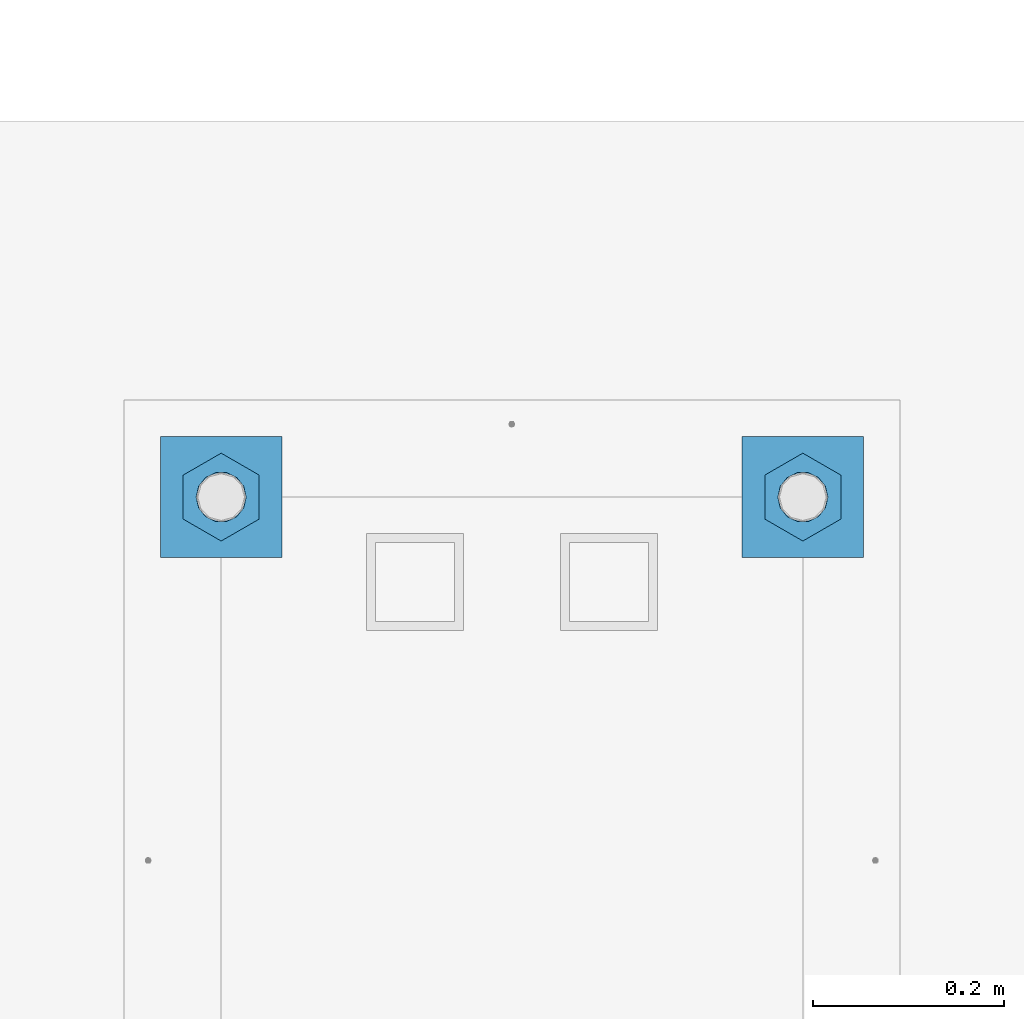
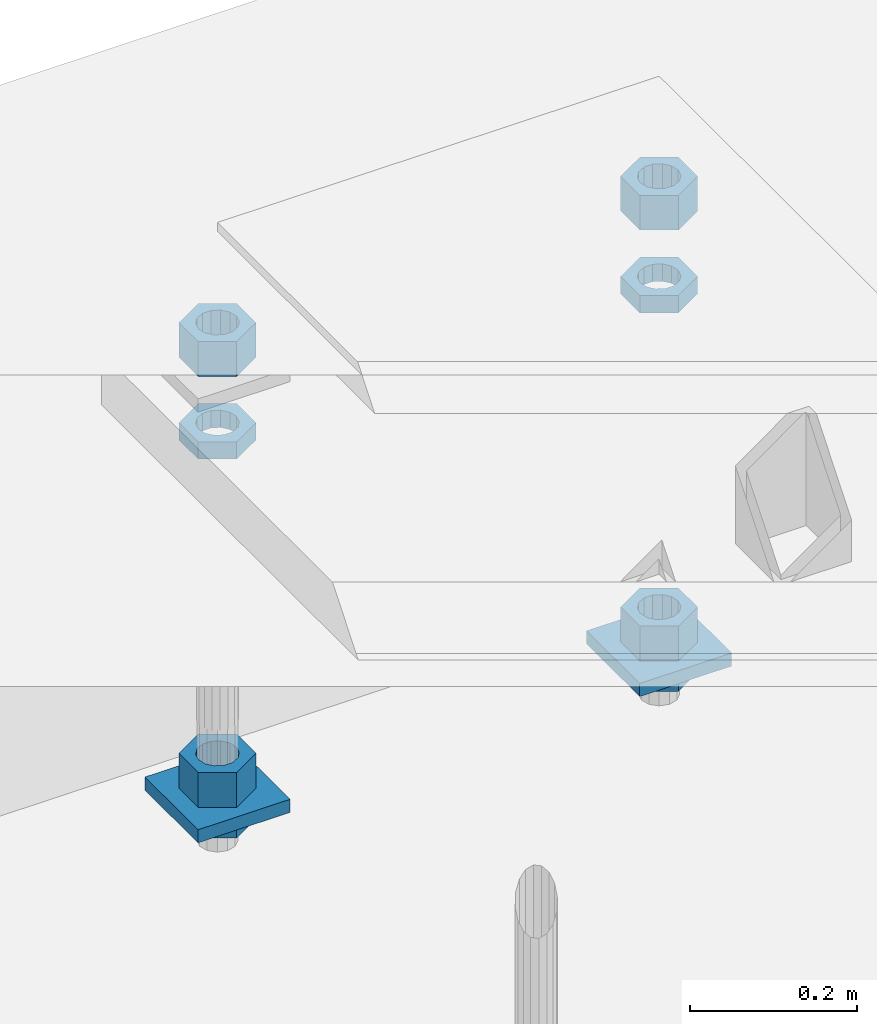
# One storey, part 2720 of 3843: 10 beams, 1 element without a shape of its own.
"""IFC2X3 building model written with IfcOpenShell, lengths in millimetres."""

from ifc_helpers import new_model, si_unit, frame, origin_with_axes, place, context, subcontext, project, spatial, faceted_brep, material, type_object, element, aggregate, save


model = new_model("IFC2X3")

# Units and contexts
model_context = context("Model", 3, precision=1e-05, world=origin_with_axes())
body_context = subcontext(model_context, "Body", "Model", "MODEL_VIEW")
ifc_project = project(units=[si_unit("LENGTHUNIT", "METRE", prefix="MILLI"), si_unit("AREAUNIT", "SQUARE_METRE"), si_unit("VOLUMEUNIT", "CUBIC_METRE"), si_unit("MASSUNIT", "GRAM", prefix="KILO"), si_unit("TIMEUNIT", "SECOND"), si_unit("PLANEANGLEUNIT", "RADIAN"), si_unit("SOLIDANGLEUNIT", "STERADIAN"), si_unit("THERMODYNAMICTEMPERATUREUNIT", "DEGREE_CELSIUS"), si_unit("LUMINOUSINTENSITYUNIT", "LUMEN")], contexts=[model_context])

# Site, building, storey
site_placement = place(None, origin_with_axes())
site = spatial("IfcSite", under=ifc_project, at=site_placement, CompositionType="ELEMENT")
building_placement = place(site_placement, origin_with_axes())
building = spatial("IfcBuilding", under=site, at=building_placement, Name="Undefined", CompositionType="ELEMENT")
storey_placement = place(building_placement, origin_with_axes())
storey = spatial("IfcBuildingStorey", under=building, at=storey_placement, Name="Undefined", CompositionType="ELEMENT", Elevation=0.0)

# Assembly, beams
assembly_placement = place(storey_placement, origin_with_axes())
assembly = element("IfcElementAssembly", 1, at=assembly_placement, inside=storey, Name="TEMPLATE", AssemblyPlace="NOTDEFINED", PredefinedType="RIGID_FRAME")
ifc_material_1 = material(Name="STEEL/A572-50")
beam_type_1 = type_object("IfcBeamType", PredefinedType="NOTDEFINED")
beam_1_placement = place(assembly_placement, frame((108585.000001526, 53086.0, 29244.925), z_axis=(0.0, -1.0, 0.0), x_axis=(1.0, 0.0, 0.0)))
beam_1 = element("IfcBeam", 2, at=beam_1_placement, type_object=beam_type_1, material=ifc_material_1, Name="WASHER_PLATE", context=body_context, shape_type="Brep", body=[
    faceted_brep([(0.0, 9.52500000000146, -63.5), (0.0, 9.52500000000146, 63.5), (127.0, 9.52500000000146, 63.5), (127.0, 9.52500000000146, -63.5), (0.0, -9.52500000000146, 63.5), (127.0, -9.52500000000146, 63.5), (0.0, -9.52500000000146, -63.5), (127.0, -9.52500000000146, -63.5)], [[[0, 1, 2, 3]], [[1, 4, 5, 2]], [[4, 6, 7, 5]], [[6, 0, 3, 7]], [[5, 7, 3, 2]], [[6, 4, 1, 0]]]),
])
beam_2_placement = place(assembly_placement, frame((109194.600001526, 53086.0, 29244.925), z_axis=(0.0, -1.0, 0.0), x_axis=(1.0, 0.0, 0.0)))
beam_2 = element("IfcBeam", 3, at=beam_2_placement, type_object=beam_type_1, material=ifc_material_1, Name="WASHER_PLATE", context=body_context, shape_type="Brep", body=[
    faceted_brep([(0.0, 9.52500000000146, -63.5), (0.0, 9.52500000000146, 63.5), (127.0, 9.52500000000146, 63.5), (127.0, 9.52500000000146, -63.5), (0.0, -9.52500000000146, 63.5), (127.0, -9.52500000000146, 63.5), (0.0, -9.52500000000146, -63.5), (127.0, -9.52500000000146, -63.5)], [[[0, 1, 2, 3]], [[1, 4, 5, 2]], [[4, 6, 7, 5]], [[6, 0, 3, 7]], [[5, 7, 3, 2]], [[6, 4, 1, 0]]]),
])
ifc_material_2 = material(Name="STEEL/A36")
beam_type_2 = type_object("IfcBeamType", Name="2_HALF_NUT", PredefinedType="NOTDEFINED")
beam_3_placement = place(assembly_placement, frame((108648.500001526, 53086.0, 29787.85), z_axis=(1.0, 0.0, 0.0), x_axis=(0.0, 0.0, -1.0)))
beam_3 = element("IfcBeam", 4, at=beam_3_placement, type_object=beam_type_2, material=ifc_material_2, Name="NUT", ObjectType="2_HALF_NUT", context=body_context, shape_type="Brep", body=[
    faceted_brep([(0.0, -46.0369987487793, 0.0), (0.0, -23.0184993743896, -39.869213104248), (25.4000000000015, -23.0184993743896, -39.869213104248), (25.4000000000015, -46.0369987487793, 0.0), (0.0, 23.0184993743896, -39.869213104248), (25.4000000000015, 23.0184993743896, -39.869213104248), (0.0, 46.0369987487793, 0.0), (25.4000000000015, 46.0369987487793, 0.0), (0.0, 23.0184993743896, 39.869213104248), (25.4000000000015, 23.0184993743896, 39.869213104248), (0.0, -23.0184993743896, 39.869213104248), (25.4000000000015, -23.0184993743896, 39.869213104248), (0.0, 0.0, 26.1940002441406), (0.0, 11.3650617044477, 23.5999013092805), (25.4000000000015, 11.3650617044477, 23.5999013092805), (25.4000000000015, 0.0, 26.1940002441406), (0.0, 20.4791109456419, 16.3316083006721), (25.4000000000015, 20.4791109456419, 16.3316083006721), (0.0, 25.5370200498292, 5.82867859874386), (25.4000000000015, 25.5370200498292, 5.82867859874386), (0.0, 25.5370200498292, -5.82867859874386), (25.4000000000015, 25.5370200498292, -5.82867859874386), (0.0, 20.4791109456419, -16.3316083006721), (25.4000000000015, 20.4791109456419, -16.3316083006721), (0.0, 11.3650617044477, -23.5999013092805), (25.4000000000015, 11.3650617044477, -23.5999013092805), (0.0, 0.0, -26.1940002441406), (25.4000000000015, 0.0, -26.1940002441406), (0.0, -11.3650617044477, -23.5999013092805), (25.4000000000015, -11.3650617044477, -23.5999013092805), (0.0, -20.4791109456419, -16.3316083006721), (25.4000000000015, -20.4791109456419, -16.3316083006721), (0.0, -25.5370200498292, -5.82867859874386), (25.4000000000015, -25.5370200498292, -5.82867859874386), (0.0, -25.5370200498292, 5.82867859874386), (25.4000000000015, -25.5370200498292, 5.82867859874386), (0.0, -20.4791109456419, 16.3316083006721), (25.4000000000015, -20.4791109456419, 16.3316083006721), (0.0, -11.3650617044477, 23.5999013092805), (25.4000000000015, -11.3650617044477, 23.5999013092805)], [[[0, 1, 2, 3]], [[1, 4, 5, 2]], [[4, 6, 7, 5]], [[6, 8, 9, 7]], [[8, 10, 11, 9]], [[10, 0, 3, 11]], [[12, 13, 14, 15]], [[13, 16, 17, 14]], [[16, 18, 19, 17]], [[18, 20, 21, 19]], [[20, 22, 23, 21]], [[22, 24, 25, 23]], [[24, 26, 27, 25]], [[26, 28, 29, 27]], [[28, 30, 31, 29]], [[30, 32, 33, 31]], [[32, 34, 35, 33]], [[34, 36, 37, 35]], [[36, 38, 39, 37]], [[38, 12, 15, 39]], [[5, 7, 9, 11, 3, 2], [17, 19, 21, 23, 25, 27, 29, 31, 33, 35, 37, 39, 15, 14]], [[10, 8, 6, 4, 1, 0], [38, 36, 34, 32, 30, 28, 26, 24, 22, 20, 18, 16, 13, 12]]]),
])
beam_4_placement = place(assembly_placement, frame((108648.500001526, 53086.0, 29235.4), z_axis=(1.0, 0.0, 0.0), x_axis=(0.0, 0.0, -1.0)))
beam_4 = element("IfcBeam", 5, at=beam_4_placement, type_object=beam_type_2, material=ifc_material_2, Name="NUT", ObjectType="2_HALF_NUT", context=body_context, shape_type="Brep", body=[
    faceted_brep([(0.0, -46.0369987487793, 0.0), (0.0, -23.0184993743896, -39.869213104248), (25.4000000000015, -23.0184993743896, -39.869213104248), (25.4000000000015, -46.0369987487793, 0.0), (0.0, 23.0184993743896, -39.869213104248), (25.4000000000015, 23.0184993743896, -39.869213104248), (0.0, 46.0369987487793, 0.0), (25.4000000000015, 46.0369987487793, 0.0), (0.0, 23.0184993743896, 39.869213104248), (25.4000000000015, 23.0184993743896, 39.869213104248), (0.0, -23.0184993743896, 39.869213104248), (25.4000000000015, -23.0184993743896, 39.869213104248), (0.0, 0.0, 26.1940002441406), (0.0, 11.3650617044477, 23.5999013092805), (25.4000000000015, 11.3650617044477, 23.5999013092805), (25.4000000000015, 0.0, 26.1940002441406), (0.0, 20.4791109456419, 16.3316083006721), (25.4000000000015, 20.4791109456419, 16.3316083006721), (0.0, 25.5370200498292, 5.82867859874386), (25.4000000000015, 25.5370200498292, 5.82867859874386), (0.0, 25.5370200498292, -5.82867859874386), (25.4000000000015, 25.5370200498292, -5.82867859874386), (0.0, 20.4791109456419, -16.3316083006721), (25.4000000000015, 20.4791109456419, -16.3316083006721), (0.0, 11.3650617044477, -23.5999013092805), (25.4000000000015, 11.3650617044477, -23.5999013092805), (0.0, 0.0, -26.1940002441406), (25.4000000000015, 0.0, -26.1940002441406), (0.0, -11.3650617044477, -23.5999013092805), (25.4000000000015, -11.3650617044477, -23.5999013092805), (0.0, -20.4791109456419, -16.3316083006721), (25.4000000000015, -20.4791109456419, -16.3316083006721), (0.0, -25.5370200498292, -5.82867859874386), (25.4000000000015, -25.5370200498292, -5.82867859874386), (0.0, -25.5370200498292, 5.82867859874386), (25.4000000000015, -25.5370200498292, 5.82867859874386), (0.0, -20.4791109456419, 16.3316083006721), (25.4000000000015, -20.4791109456419, 16.3316083006721), (0.0, -11.3650617044477, 23.5999013092805), (25.4000000000015, -11.3650617044477, 23.5999013092805)], [[[0, 1, 2, 3]], [[1, 4, 5, 2]], [[4, 6, 7, 5]], [[6, 8, 9, 7]], [[8, 10, 11, 9]], [[10, 0, 3, 11]], [[12, 13, 14, 15]], [[13, 16, 17, 14]], [[16, 18, 19, 17]], [[18, 20, 21, 19]], [[20, 22, 23, 21]], [[22, 24, 25, 23]], [[24, 26, 27, 25]], [[26, 28, 29, 27]], [[28, 30, 31, 29]], [[30, 32, 33, 31]], [[32, 34, 35, 33]], [[34, 36, 37, 35]], [[36, 38, 39, 37]], [[38, 12, 15, 39]], [[5, 7, 9, 11, 3, 2], [17, 19, 21, 23, 25, 27, 29, 31, 33, 35, 37, 39, 15, 14]], [[10, 8, 6, 4, 1, 0], [38, 36, 34, 32, 30, 28, 26, 24, 22, 20, 18, 16, 13, 12]]]),
])
beam_5_placement = place(assembly_placement, frame((109258.100001526, 53086.0, 29787.85), z_axis=(1.0, 0.0, 0.0), x_axis=(0.0, 0.0, -1.0)))
beam_5 = element("IfcBeam", 6, at=beam_5_placement, type_object=beam_type_2, material=ifc_material_2, Name="NUT", ObjectType="2_HALF_NUT", context=body_context, shape_type="Brep", body=[
    faceted_brep([(0.0, -46.0369987487793, 0.0), (0.0, -23.0184993743896, -39.869213104248), (25.4000000000015, -23.0184993743896, -39.869213104248), (25.4000000000015, -46.0369987487793, 0.0), (0.0, 23.0184993743896, -39.869213104248), (25.4000000000015, 23.0184993743896, -39.869213104248), (0.0, 46.0369987487793, 0.0), (25.4000000000015, 46.0369987487793, 0.0), (0.0, 23.0184993743896, 39.869213104248), (25.4000000000015, 23.0184993743896, 39.869213104248), (0.0, -23.0184993743896, 39.869213104248), (25.4000000000015, -23.0184993743896, 39.869213104248), (0.0, 0.0, 26.1940002441406), (0.0, 11.3650617044477, 23.5999013092805), (25.4000000000015, 11.3650617044477, 23.5999013092805), (25.4000000000015, 0.0, 26.1940002441406), (0.0, 20.4791109456419, 16.3316083006721), (25.4000000000015, 20.4791109456419, 16.3316083006721), (0.0, 25.5370200498292, 5.82867859874386), (25.4000000000015, 25.5370200498292, 5.82867859874386), (0.0, 25.5370200498292, -5.82867859874386), (25.4000000000015, 25.5370200498292, -5.82867859874386), (0.0, 20.4791109456419, -16.3316083006721), (25.4000000000015, 20.4791109456419, -16.3316083006721), (0.0, 11.3650617044477, -23.5999013092805), (25.4000000000015, 11.3650617044477, -23.5999013092805), (0.0, 0.0, -26.1940002441406), (25.4000000000015, 0.0, -26.1940002441406), (0.0, -11.3650617044477, -23.5999013092805), (25.4000000000015, -11.3650617044477, -23.5999013092805), (0.0, -20.4791109456419, -16.3316083006721), (25.4000000000015, -20.4791109456419, -16.3316083006721), (0.0, -25.5370200498292, -5.82867859874386), (25.4000000000015, -25.5370200498292, -5.82867859874386), (0.0, -25.5370200498292, 5.82867859874386), (25.4000000000015, -25.5370200498292, 5.82867859874386), (0.0, -20.4791109456419, 16.3316083006721), (25.4000000000015, -20.4791109456419, 16.3316083006721), (0.0, -11.3650617044477, 23.5999013092805), (25.4000000000015, -11.3650617044477, 23.5999013092805)], [[[0, 1, 2, 3]], [[1, 4, 5, 2]], [[4, 6, 7, 5]], [[6, 8, 9, 7]], [[8, 10, 11, 9]], [[10, 0, 3, 11]], [[12, 13, 14, 15]], [[13, 16, 17, 14]], [[16, 18, 19, 17]], [[18, 20, 21, 19]], [[20, 22, 23, 21]], [[22, 24, 25, 23]], [[24, 26, 27, 25]], [[26, 28, 29, 27]], [[28, 30, 31, 29]], [[30, 32, 33, 31]], [[32, 34, 35, 33]], [[34, 36, 37, 35]], [[36, 38, 39, 37]], [[38, 12, 15, 39]], [[5, 7, 9, 11, 3, 2], [17, 19, 21, 23, 25, 27, 29, 31, 33, 35, 37, 39, 15, 14]], [[10, 8, 6, 4, 1, 0], [38, 36, 34, 32, 30, 28, 26, 24, 22, 20, 18, 16, 13, 12]]]),
])
beam_6_placement = place(assembly_placement, frame((109258.100001526, 53086.0, 29235.4), z_axis=(1.0, 0.0, 0.0), x_axis=(0.0, 0.0, -1.0)))
beam_6 = element("IfcBeam", 7, at=beam_6_placement, type_object=beam_type_2, material=ifc_material_2, Name="NUT", ObjectType="2_HALF_NUT", context=body_context, shape_type="Brep", body=[
    faceted_brep([(0.0, -46.0369987487793, 0.0), (0.0, -23.0184993743896, -39.869213104248), (25.4000000000015, -23.0184993743896, -39.869213104248), (25.4000000000015, -46.0369987487793, 0.0), (0.0, 23.0184993743896, -39.869213104248), (25.4000000000015, 23.0184993743896, -39.869213104248), (0.0, 46.0369987487793, 0.0), (25.4000000000015, 46.0369987487793, 0.0), (0.0, 23.0184993743896, 39.869213104248), (25.4000000000015, 23.0184993743896, 39.869213104248), (0.0, -23.0184993743896, 39.869213104248), (25.4000000000015, -23.0184993743896, 39.869213104248), (0.0, 0.0, 26.1940002441406), (0.0, 11.3650617044477, 23.5999013092805), (25.4000000000015, 11.3650617044477, 23.5999013092805), (25.4000000000015, 0.0, 26.1940002441406), (0.0, 20.4791109456419, 16.3316083006721), (25.4000000000015, 20.4791109456419, 16.3316083006721), (0.0, 25.5370200498292, 5.82867859874386), (25.4000000000015, 25.5370200498292, 5.82867859874386), (0.0, 25.5370200498292, -5.82867859874386), (25.4000000000015, 25.5370200498292, -5.82867859874386), (0.0, 20.4791109456419, -16.3316083006721), (25.4000000000015, 20.4791109456419, -16.3316083006721), (0.0, 11.3650617044477, -23.5999013092805), (25.4000000000015, 11.3650617044477, -23.5999013092805), (0.0, 0.0, -26.1940002441406), (25.4000000000015, 0.0, -26.1940002441406), (0.0, -11.3650617044477, -23.5999013092805), (25.4000000000015, -11.3650617044477, -23.5999013092805), (0.0, -20.4791109456419, -16.3316083006721), (25.4000000000015, -20.4791109456419, -16.3316083006721), (0.0, -25.5370200498292, -5.82867859874386), (25.4000000000015, -25.5370200498292, -5.82867859874386), (0.0, -25.5370200498292, 5.82867859874386), (25.4000000000015, -25.5370200498292, 5.82867859874386), (0.0, -20.4791109456419, 16.3316083006721), (25.4000000000015, -20.4791109456419, 16.3316083006721), (0.0, -11.3650617044477, 23.5999013092805), (25.4000000000015, -11.3650617044477, 23.5999013092805)], [[[0, 1, 2, 3]], [[1, 4, 5, 2]], [[4, 6, 7, 5]], [[6, 8, 9, 7]], [[8, 10, 11, 9]], [[10, 0, 3, 11]], [[12, 13, 14, 15]], [[13, 16, 17, 14]], [[16, 18, 19, 17]], [[18, 20, 21, 19]], [[20, 22, 23, 21]], [[22, 24, 25, 23]], [[24, 26, 27, 25]], [[26, 28, 29, 27]], [[28, 30, 31, 29]], [[30, 32, 33, 31]], [[32, 34, 35, 33]], [[34, 36, 37, 35]], [[36, 38, 39, 37]], [[38, 12, 15, 39]], [[5, 7, 9, 11, 3, 2], [17, 19, 21, 23, 25, 27, 29, 31, 33, 35, 37, 39, 15, 14]], [[10, 8, 6, 4, 1, 0], [38, 36, 34, 32, 30, 28, 26, 24, 22, 20, 18, 16, 13, 12]]]),
])
beam_type_3 = type_object("IfcBeamType", Name="2_HEAVY_HEX_NUT", PredefinedType="NOTDEFINED")
beam_7_placement = place(assembly_placement, frame((108648.500001526, 53086.0, 29933.9), z_axis=(1.0, 0.0, 0.0), x_axis=(0.0, 0.0, -1.0)))
beam_7 = element("IfcBeam", 8, at=beam_7_placement, type_object=beam_type_3, material=ifc_material_2, Name="NUT", ObjectType="2_HEAVY_HEX_NUT", context=body_context, shape_type="Brep", body=[
    faceted_brep([(0.0, -46.0369987487793, 0.0), (0.0, -23.0184993743896, -39.869213104248), (50.7999999999993, -23.0184993743896, -39.869213104248), (50.7999999999993, -46.0369987487793, 0.0), (0.0, 23.0184993743896, -39.869213104248), (50.7999999999993, 23.0184993743896, -39.869213104248), (0.0, 46.0369987487793, 0.0), (50.7999999999993, 46.0369987487793, 0.0), (0.0, 23.0184993743896, 39.869213104248), (50.7999999999993, 23.0184993743896, 39.869213104248), (0.0, -23.0184993743896, 39.869213104248), (50.7999999999993, -23.0184993743896, 39.869213104248), (0.0, 0.0, 26.1940002441406), (0.0, 11.3650617044477, 23.5999013092805), (50.7999999999993, 11.3650617044477, 23.5999013092805), (50.7999999999993, 0.0, 26.1940002441406), (0.0, 20.4791109456419, 16.3316083006721), (50.7999999999993, 20.4791109456419, 16.3316083006721), (0.0, 25.5370200498292, 5.82867859874386), (50.7999999999993, 25.5370200498292, 5.82867859874386), (0.0, 25.5370200498292, -5.82867859874386), (50.7999999999993, 25.5370200498292, -5.82867859874386), (0.0, 20.4791109456419, -16.3316083006721), (50.7999999999993, 20.4791109456419, -16.3316083006721), (0.0, 11.3650617044477, -23.5999013092805), (50.7999999999993, 11.3650617044477, -23.5999013092805), (0.0, 0.0, -26.1940002441406), (50.7999999999993, 0.0, -26.1940002441406), (0.0, -11.3650617044477, -23.5999013092805), (50.7999999999993, -11.3650617044477, -23.5999013092805), (0.0, -20.4791109456419, -16.3316083006721), (50.7999999999993, -20.4791109456419, -16.3316083006721), (0.0, -25.5370200498292, -5.82867859874386), (50.7999999999993, -25.5370200498292, -5.82867859874386), (0.0, -25.5370200498292, 5.82867859874386), (50.7999999999993, -25.5370200498292, 5.82867859874386), (0.0, -20.4791109456419, 16.3316083006721), (50.7999999999993, -20.4791109456419, 16.3316083006721), (0.0, -11.3650617044477, 23.5999013092805), (50.7999999999993, -11.3650617044477, 23.5999013092805)], [[[0, 1, 2, 3]], [[1, 4, 5, 2]], [[4, 6, 7, 5]], [[6, 8, 9, 7]], [[8, 10, 11, 9]], [[10, 0, 3, 11]], [[12, 13, 14, 15]], [[13, 16, 17, 14]], [[16, 18, 19, 17]], [[18, 20, 21, 19]], [[20, 22, 23, 21]], [[22, 24, 25, 23]], [[24, 26, 27, 25]], [[26, 28, 29, 27]], [[28, 30, 31, 29]], [[30, 32, 33, 31]], [[32, 34, 35, 33]], [[34, 36, 37, 35]], [[36, 38, 39, 37]], [[38, 12, 15, 39]], [[5, 7, 9, 11, 3, 2], [17, 19, 21, 23, 25, 27, 29, 31, 33, 35, 37, 39, 15, 14]], [[10, 8, 6, 4, 1, 0], [38, 36, 34, 32, 30, 28, 26, 24, 22, 20, 18, 16, 13, 12]]]),
])
beam_8_placement = place(assembly_placement, frame((108648.500001526, 53086.0, 29305.25), z_axis=(1.0, 0.0, 0.0), x_axis=(0.0, 0.0, -1.0)))
beam_8 = element("IfcBeam", 9, at=beam_8_placement, type_object=beam_type_3, material=ifc_material_2, Name="NUT", ObjectType="2_HEAVY_HEX_NUT", context=body_context, shape_type="Brep", body=[
    faceted_brep([(0.0, -46.0369987487793, 0.0), (0.0, -23.0184993743896, -39.869213104248), (50.7999999999993, -23.0184993743896, -39.869213104248), (50.7999999999993, -46.0369987487793, 0.0), (0.0, 23.0184993743896, -39.869213104248), (50.7999999999993, 23.0184993743896, -39.869213104248), (0.0, 46.0369987487793, 0.0), (50.7999999999993, 46.0369987487793, 0.0), (0.0, 23.0184993743896, 39.869213104248), (50.7999999999993, 23.0184993743896, 39.869213104248), (0.0, -23.0184993743896, 39.869213104248), (50.7999999999993, -23.0184993743896, 39.869213104248), (0.0, 0.0, 26.1940002441406), (0.0, 11.3650617044477, 23.5999013092805), (50.7999999999993, 11.3650617044477, 23.5999013092805), (50.7999999999993, 0.0, 26.1940002441406), (0.0, 20.4791109456419, 16.3316083006721), (50.7999999999993, 20.4791109456419, 16.3316083006721), (0.0, 25.5370200498292, 5.82867859874386), (50.7999999999993, 25.5370200498292, 5.82867859874386), (0.0, 25.5370200498292, -5.82867859874386), (50.7999999999993, 25.5370200498292, -5.82867859874386), (0.0, 20.4791109456419, -16.3316083006721), (50.7999999999993, 20.4791109456419, -16.3316083006721), (0.0, 11.3650617044477, -23.5999013092805), (50.7999999999993, 11.3650617044477, -23.5999013092805), (0.0, 0.0, -26.1940002441406), (50.7999999999993, 0.0, -26.1940002441406), (0.0, -11.3650617044477, -23.5999013092805), (50.7999999999993, -11.3650617044477, -23.5999013092805), (0.0, -20.4791109456419, -16.3316083006721), (50.7999999999993, -20.4791109456419, -16.3316083006721), (0.0, -25.5370200498292, -5.82867859874386), (50.7999999999993, -25.5370200498292, -5.82867859874386), (0.0, -25.5370200498292, 5.82867859874386), (50.7999999999993, -25.5370200498292, 5.82867859874386), (0.0, -20.4791109456419, 16.3316083006721), (50.7999999999993, -20.4791109456419, 16.3316083006721), (0.0, -11.3650617044477, 23.5999013092805), (50.7999999999993, -11.3650617044477, 23.5999013092805)], [[[0, 1, 2, 3]], [[1, 4, 5, 2]], [[4, 6, 7, 5]], [[6, 8, 9, 7]], [[8, 10, 11, 9]], [[10, 0, 3, 11]], [[12, 13, 14, 15]], [[13, 16, 17, 14]], [[16, 18, 19, 17]], [[18, 20, 21, 19]], [[20, 22, 23, 21]], [[22, 24, 25, 23]], [[24, 26, 27, 25]], [[26, 28, 29, 27]], [[28, 30, 31, 29]], [[30, 32, 33, 31]], [[32, 34, 35, 33]], [[34, 36, 37, 35]], [[36, 38, 39, 37]], [[38, 12, 15, 39]], [[5, 7, 9, 11, 3, 2], [17, 19, 21, 23, 25, 27, 29, 31, 33, 35, 37, 39, 15, 14]], [[10, 8, 6, 4, 1, 0], [38, 36, 34, 32, 30, 28, 26, 24, 22, 20, 18, 16, 13, 12]]]),
])
beam_9_placement = place(assembly_placement, frame((109258.100001526, 53086.0, 29933.9), z_axis=(1.0, 0.0, 0.0), x_axis=(0.0, 0.0, -1.0)))
beam_9 = element("IfcBeam", 10, at=beam_9_placement, type_object=beam_type_3, material=ifc_material_2, Name="NUT", ObjectType="2_HEAVY_HEX_NUT", context=body_context, shape_type="Brep", body=[
    faceted_brep([(0.0, -46.0369987487793, 0.0), (0.0, -23.0184993743896, -39.869213104248), (50.7999999999993, -23.0184993743896, -39.869213104248), (50.7999999999993, -46.0369987487793, 0.0), (0.0, 23.0184993743896, -39.869213104248), (50.7999999999993, 23.0184993743896, -39.869213104248), (0.0, 46.0369987487793, 0.0), (50.7999999999993, 46.0369987487793, 0.0), (0.0, 23.0184993743896, 39.869213104248), (50.7999999999993, 23.0184993743896, 39.869213104248), (0.0, -23.0184993743896, 39.869213104248), (50.7999999999993, -23.0184993743896, 39.869213104248), (0.0, 0.0, 26.1940002441406), (0.0, 11.3650617044477, 23.5999013092805), (50.7999999999993, 11.3650617044477, 23.5999013092805), (50.7999999999993, 0.0, 26.1940002441406), (0.0, 20.4791109456419, 16.3316083006721), (50.7999999999993, 20.4791109456419, 16.3316083006721), (0.0, 25.5370200498292, 5.82867859874386), (50.7999999999993, 25.5370200498292, 5.82867859874386), (0.0, 25.5370200498292, -5.82867859874386), (50.7999999999993, 25.5370200498292, -5.82867859874386), (0.0, 20.4791109456419, -16.3316083006721), (50.7999999999993, 20.4791109456419, -16.3316083006721), (0.0, 11.3650617044477, -23.5999013092805), (50.7999999999993, 11.3650617044477, -23.5999013092805), (0.0, 0.0, -26.1940002441406), (50.7999999999993, 0.0, -26.1940002441406), (0.0, -11.3650617044477, -23.5999013092805), (50.7999999999993, -11.3650617044477, -23.5999013092805), (0.0, -20.4791109456419, -16.3316083006721), (50.7999999999993, -20.4791109456419, -16.3316083006721), (0.0, -25.5370200498292, -5.82867859874386), (50.7999999999993, -25.5370200498292, -5.82867859874386), (0.0, -25.5370200498292, 5.82867859874386), (50.7999999999993, -25.5370200498292, 5.82867859874386), (0.0, -20.4791109456419, 16.3316083006721), (50.7999999999993, -20.4791109456419, 16.3316083006721), (0.0, -11.3650617044477, 23.5999013092805), (50.7999999999993, -11.3650617044477, 23.5999013092805)], [[[0, 1, 2, 3]], [[1, 4, 5, 2]], [[4, 6, 7, 5]], [[6, 8, 9, 7]], [[8, 10, 11, 9]], [[10, 0, 3, 11]], [[12, 13, 14, 15]], [[13, 16, 17, 14]], [[16, 18, 19, 17]], [[18, 20, 21, 19]], [[20, 22, 23, 21]], [[22, 24, 25, 23]], [[24, 26, 27, 25]], [[26, 28, 29, 27]], [[28, 30, 31, 29]], [[30, 32, 33, 31]], [[32, 34, 35, 33]], [[34, 36, 37, 35]], [[36, 38, 39, 37]], [[38, 12, 15, 39]], [[5, 7, 9, 11, 3, 2], [17, 19, 21, 23, 25, 27, 29, 31, 33, 35, 37, 39, 15, 14]], [[10, 8, 6, 4, 1, 0], [38, 36, 34, 32, 30, 28, 26, 24, 22, 20, 18, 16, 13, 12]]]),
])
beam_10_placement = place(assembly_placement, frame((109258.100001526, 53086.0, 29305.25), z_axis=(1.0, 0.0, 0.0), x_axis=(0.0, 0.0, -1.0)))
beam_10 = element("IfcBeam", 11, at=beam_10_placement, type_object=beam_type_3, material=ifc_material_2, Name="NUT", ObjectType="2_HEAVY_HEX_NUT", context=body_context, shape_type="Brep", body=[
    faceted_brep([(0.0, -46.0369987487793, 0.0), (0.0, -23.0184993743896, -39.869213104248), (50.7999999999993, -23.0184993743896, -39.869213104248), (50.7999999999993, -46.0369987487793, 0.0), (0.0, 23.0184993743896, -39.869213104248), (50.7999999999993, 23.0184993743896, -39.869213104248), (0.0, 46.0369987487793, 0.0), (50.7999999999993, 46.0369987487793, 0.0), (0.0, 23.0184993743896, 39.869213104248), (50.7999999999993, 23.0184993743896, 39.869213104248), (0.0, -23.0184993743896, 39.869213104248), (50.7999999999993, -23.0184993743896, 39.869213104248), (0.0, 0.0, 26.1940002441406), (0.0, 11.3650617044477, 23.5999013092805), (50.7999999999993, 11.3650617044477, 23.5999013092805), (50.7999999999993, 0.0, 26.1940002441406), (0.0, 20.4791109456419, 16.3316083006721), (50.7999999999993, 20.4791109456419, 16.3316083006721), (0.0, 25.5370200498292, 5.82867859874386), (50.7999999999993, 25.5370200498292, 5.82867859874386), (0.0, 25.5370200498292, -5.82867859874386), (50.7999999999993, 25.5370200498292, -5.82867859874386), (0.0, 20.4791109456419, -16.3316083006721), (50.7999999999993, 20.4791109456419, -16.3316083006721), (0.0, 11.3650617044477, -23.5999013092805), (50.7999999999993, 11.3650617044477, -23.5999013092805), (0.0, 0.0, -26.1940002441406), (50.7999999999993, 0.0, -26.1940002441406), (0.0, -11.3650617044477, -23.5999013092805), (50.7999999999993, -11.3650617044477, -23.5999013092805), (0.0, -20.4791109456419, -16.3316083006721), (50.7999999999993, -20.4791109456419, -16.3316083006721), (0.0, -25.5370200498292, -5.82867859874386), (50.7999999999993, -25.5370200498292, -5.82867859874386), (0.0, -25.5370200498292, 5.82867859874386), (50.7999999999993, -25.5370200498292, 5.82867859874386), (0.0, -20.4791109456419, 16.3316083006721), (50.7999999999993, -20.4791109456419, 16.3316083006721), (0.0, -11.3650617044477, 23.5999013092805), (50.7999999999993, -11.3650617044477, 23.5999013092805)], [[[0, 1, 2, 3]], [[1, 4, 5, 2]], [[4, 6, 7, 5]], [[6, 8, 9, 7]], [[8, 10, 11, 9]], [[10, 0, 3, 11]], [[12, 13, 14, 15]], [[13, 16, 17, 14]], [[16, 18, 19, 17]], [[18, 20, 21, 19]], [[20, 22, 23, 21]], [[22, 24, 25, 23]], [[24, 26, 27, 25]], [[26, 28, 29, 27]], [[28, 30, 31, 29]], [[30, 32, 33, 31]], [[32, 34, 35, 33]], [[34, 36, 37, 35]], [[36, 38, 39, 37]], [[38, 12, 15, 39]], [[5, 7, 9, 11, 3, 2], [17, 19, 21, 23, 25, 27, 29, 31, 33, 35, 37, 39, 15, 14]], [[10, 8, 6, 4, 1, 0], [38, 36, 34, 32, 30, 28, 26, 24, 22, 20, 18, 16, 13, 12]]]),
])
aggregate(assembly, [beam_3, beam_7, beam_8, beam_4, beam_1, beam_5, beam_9, beam_10, beam_6, beam_2])

save(model, "model.ifc")
